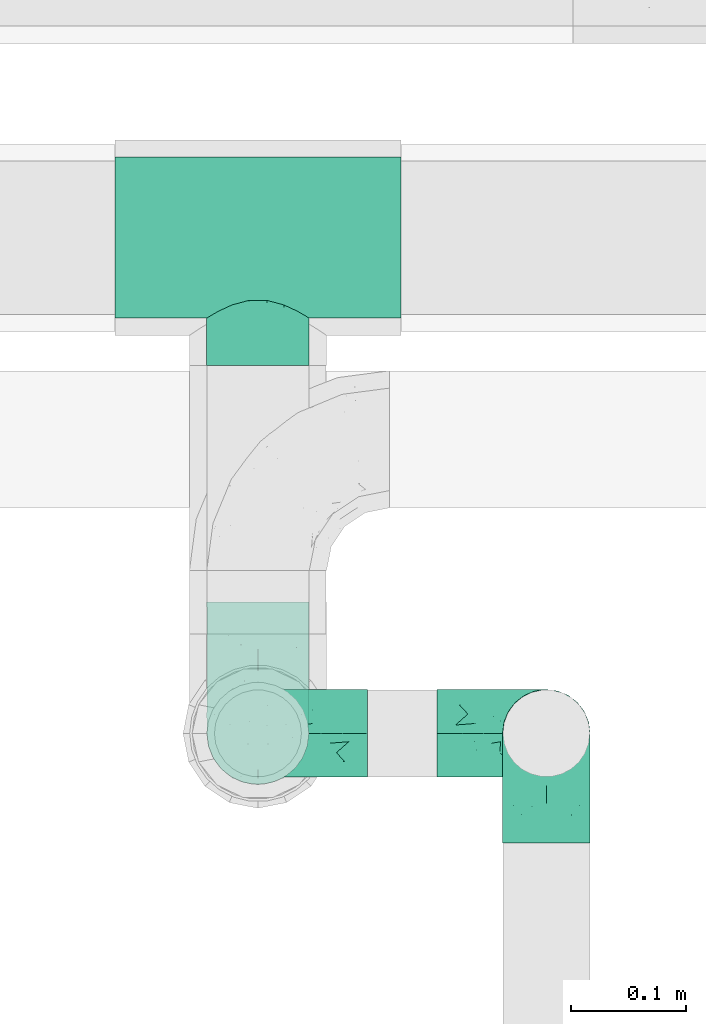
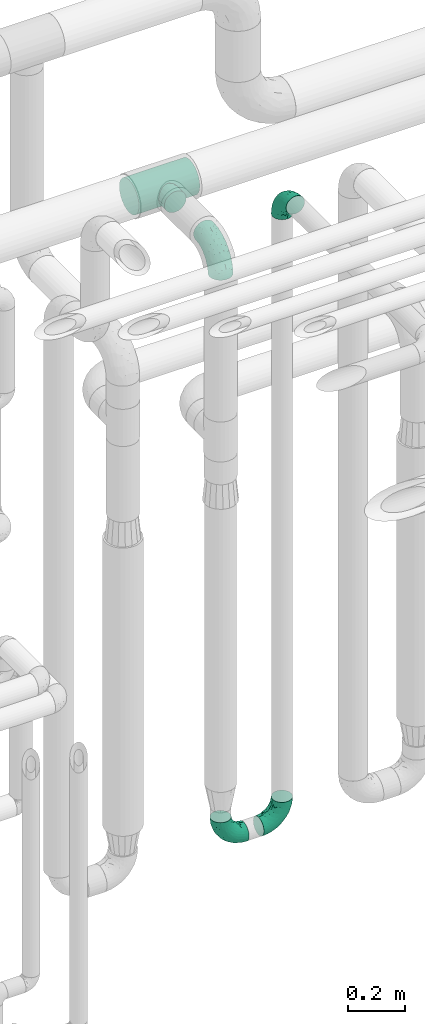
# One storey, part 706 of 827: 5 flow fittings.
"""IFC2X3 building model written with IfcOpenShell, lengths in millimetres."""

import ifcopenshell
import ifcopenshell.guid

model = None  # the IFC model being written
_history = None  # IfcOwnerHistory: only IFC2X3 demands one
_inside = {}  # id of a spatial element -> (the spatial element, [elements in it])
_under = {}  # id of a project, library or spatial element -> (it, [spatial elements below it])
_declared = {}  # id of a project -> (the project, [libraries it declares])
_typed = {}  # id of a type object -> (the type object, [elements of that type])
_made_of = {}  # id of a material, layer set ... -> (it, [elements and type objects made of it])


def new_model(schema):
    """Start an empty IFC model of exactly this schema.

    Asked for "IFC4X3", IfcOpenShell would pick the latest addendum, in which some entities
    have other attributes; the version numbers below select the first issue.
    IFC2X3 requires an IfcOwnerHistory on every rooted entity: one is made here for all.
    """
    global model, _history
    if schema == "IFC4X3":
        model = ifcopenshell.file(schema_version=(4, 3, 0, 0))
    else:
        model = ifcopenshell.file(schema=schema)
    _inside.clear()
    _under.clear()
    _declared.clear()
    _typed.clear()
    _made_of.clear()
    _history = None
    if model.schema == "IFC2X3":
        org = make("IfcOrganization", Name="unknown")
        user = make(
            "IfcPersonAndOrganization",
            ThePerson=make("IfcPerson", FamilyName="unknown"),
            TheOrganization=org,
        )
        app = make(
            "IfcApplication",
            ApplicationDeveloper=org,
            Version="unknown",
            ApplicationFullName="unknown",
            ApplicationIdentifier="unknown",
        )
        _history = make(
            "IfcOwnerHistory",
            OwningUser=user,
            OwningApplication=app,
            ChangeAction="ADDED",
            CreationDate=0,
        )
    return model


def make(cls, **values):
    """One entity of the class cls with the attributes given. An attribute that is None is left unset."""
    return model.create_entity(
        cls, **{name: value for name, value in values.items() if value is not None}
    )


def entity(cls, *values):
    """Any entity or typed value of the class cls, its attributes in the order of the schema. None: left unset."""
    e = model.create_entity(cls)
    for i, value in enumerate(values):
        if value is not None:
            e[i] = value
    return e


def rooted(cls, **values):
    """An entity with a GlobalId (a new one), such as an element, a storey or a relation."""
    return make(cls, GlobalId=ifcopenshell.guid.new(), OwnerHistory=_history, **values)


def si_unit(unit_type, name, prefix=None):
    """IfcSIUnit, for example si_unit("LENGTHUNIT", "METRE", prefix="MILLI")."""
    return make("IfcSIUnit", UnitType=unit_type, Prefix=prefix, Name=name)


def converted_unit(unit_type, name, factor, base, dimensions=None, offset=None):
    """IfcConversionBasedUnit, such as the inch: factor (a typed value) times the base unit."""
    return make(
        "IfcConversionBasedUnit"
        if offset is None
        else "IfcConversionBasedUnitWithOffset",
        ConversionOffset=offset,
        Dimensions=None
        if dimensions is None
        else entity("IfcDimensionalExponents", *dimensions),
        UnitType=unit_type,
        Name=name,
        ConversionFactor=make(
            "IfcMeasureWithUnit", ValueComponent=factor, UnitComponent=base
        ),
    )


def derived_unit(unit_type, elements):
    """IfcDerivedUnit: a product of units, each with its exponent."""
    return make(
        "IfcDerivedUnit",
        Elements=[
            make("IfcDerivedUnitElement", Unit=unit, Exponent=power)
            for unit, power in elements
        ],
        UnitType=unit_type,
    )


def assignment(units):
    """IfcUnitAssignment: the units of a project."""
    return None if units is None else make("IfcUnitAssignment", Units=units)


def point(xyz):
    """IfcCartesianPoint."""
    return None if xyz is None else make("IfcCartesianPoint", Coordinates=xyz)


def direction(xyz):
    """IfcDirection."""
    return None if xyz is None else make("IfcDirection", DirectionRatios=xyz)


def frame(location, z_axis=None, x_axis=None):
    """IfcAxis2Placement3D, a coordinate frame: its origin and axes. An axis left out is left unset."""
    return make(
        "IfcAxis2Placement3D",
        Location=point(location),
        Axis=direction(z_axis),
        RefDirection=direction(x_axis),
    )


def origin():
    """The frame at (0, 0, 0) with its axes left unset."""
    return frame((0.0, 0.0, 0.0))


def place(relative_to, where):
    """IfcLocalPlacement: puts the frame where relative to a parent placement (None: the world)."""
    return make(
        "IfcLocalPlacement", PlacementRelTo=relative_to, RelativePlacement=where
    )


def context(
    kind, dimensions, precision=None, world=None, true_north=None, identifier=None
):
    """IfcGeometricRepresentationContext, for example the 3D "Model" context."""
    return make(
        "IfcGeometricRepresentationContext",
        ContextIdentifier=identifier,
        ContextType=kind,
        CoordinateSpaceDimension=dimensions,
        Precision=precision,
        WorldCoordinateSystem=world,
        TrueNorth=true_north,
    )


def subcontext(parent, identifier, kind, view, scale=None):
    """IfcGeometricRepresentationSubContext, for example "Body" below "Model"."""
    return make(
        "IfcGeometricRepresentationSubContext",
        ContextIdentifier=identifier,
        ContextType=kind,
        ParentContext=parent,
        TargetScale=scale,
        TargetView=view,
    )


def project(units=None, contexts=None):
    """IfcProject with its units and contexts."""
    return rooted(
        "IfcProject",
        Name="project",
        RepresentationContexts=contexts,
        UnitsInContext=assignment(units),
    )


def spatial(cls, under=None, at=None, **own):
    """A site, building, storey or space (cls), placed at a placement, below another one or the project."""
    s = rooted(cls, ObjectPlacement=at, **own)
    if under is not None:
        _under.setdefault(under.id(), (under, []))[1].append(s)
    return s


def faces_of(points, faces, orient=None, outer=None):
    """IfcFace entities. A face is a list of loops; a loop is a list of indices into points, from 0.

    orient and outer hold one flag for each loop. By default every Orientation is true, the
    first loop of a face is its IfcFaceOuterBound and the others are IfcFaceBound.
    """
    made = []
    for i, loops in enumerate(faces):
        bounds = []
        for j, loop in enumerate(loops):
            is_outer = j == 0 if outer is None else outer[i][j]
            bounds.append(
                make(
                    "IfcFaceOuterBound" if is_outer else "IfcFaceBound",
                    Bound=make("IfcPolyLoop", Polygon=[points[k] for k in loop]),
                    Orientation=True if orient is None else orient[i][j],
                )
            )
        made.append(make("IfcFace", Bounds=bounds))
    return made


def faceted_brep(points, faces, orient=None, outer=None, voids=None):
    """IfcFacetedBrep: a solid bounded by flat faces; with voids (closed shells), ...WithVoids."""
    shared = [point(p) for p in points]
    hull = make("IfcClosedShell", CfsFaces=faces_of(shared, faces, orient, outer))
    if voids is None:
        return make("IfcFacetedBrep", Outer=hull)
    return make(
        "IfcFacetedBrepWithVoids",
        Outer=hull,
        Voids=[
            make(cls, CfsFaces=faces_of(shared, fs, o, b)) for cls, fs, o, b in voids
        ],
    )


def shape(context_of_items, identifier, shape_type, items):
    """IfcShapeRepresentation: the items that make up one representation, for example the "Body"."""
    return make(
        "IfcShapeRepresentation",
        ContextOfItems=context_of_items,
        RepresentationIdentifier=identifier,
        RepresentationType=shape_type,
        Items=items,
    )


def source(mapping_origin, context_of_items, identifier, shape_type, items):
    """IfcRepresentationMap: a shape defined once, which mapped items show again and again."""
    return make(
        "IfcRepresentationMap",
        MappingOrigin=mapping_origin,
        MappedRepresentation=shape(context_of_items, identifier, shape_type, items),
    )


def transform(
    local_origin,
    x_axis=None,
    y_axis=None,
    z_axis=None,
    scale=None,
    scale2=None,
    scale3=None,
    uniform=True,
):
    """IfcCartesianTransformationOperator3D, or its non-uniform kind. x_axis, y_axis, z_axis: its Axis1, 2, 3."""
    if uniform:
        return make(
            "IfcCartesianTransformationOperator3D",
            Axis1=direction(x_axis),
            Axis2=direction(y_axis),
            LocalOrigin=point(local_origin),
            Scale=scale,
            Axis3=direction(z_axis),
        )
    return make(
        "IfcCartesianTransformationOperator3DnonUniform",
        Axis1=direction(x_axis),
        Axis2=direction(y_axis),
        LocalOrigin=point(local_origin),
        Scale=scale,
        Axis3=direction(z_axis),
        Scale2=scale2,
        Scale3=scale3,
    )


def mapped(mapping_source, mapping_target):
    """IfcMappedItem: shows the shape of a source again, moved by a transform."""
    return make(
        "IfcMappedItem", MappingSource=mapping_source, MappingTarget=mapping_target
    )


def material(Name=None, Category=None):
    """IfcMaterial."""
    return make("IfcMaterial", Name=Name, Category=Category)


def made_of(thing, what):
    """Note that an element or type object is made of a material, layer set ...; save() writes the relation."""
    if what is not None:
        _made_of.setdefault(what.id(), (what, []))[1].append(thing)
    return thing


def type_object(cls, material=None, **own):
    """A type object (cls), such as IfcWallType, which elements share."""
    return made_of(rooted(cls, **own), material)


def type_shapes(of_type, sources):
    """Give a type object the sources (RepresentationMaps) that its elements show as mapped items."""
    of_type.RepresentationMaps = sources


def element(
    cls,
    number,
    at=None,
    inside=None,
    cuts=None,
    type_object=None,
    material=None,
    context=None,
    identifier="Body",
    shape_type=None,
    held_by="IfcProductDefinitionShape",
    body=None,
    shapes=None,
    **own,
):
    """One element of the class cls, such as IfcWall. Its Tag is "e" and its number.

    at: its placement. inside: the storey or other place that contains it. cuts: it is an
    opening in that element (IfcRelVoidsElement). A single representation is given by context,
    identifier, shape_type and body (its items); several are given by shapes. held_by: the class
    of the entity that holds the representations. save() writes the other relations.
    """
    e = rooted(cls, Tag="e%d" % number, ObjectPlacement=at, **own)
    if body is not None:
        shapes = [shape(context, identifier, shape_type, body)]
    if shapes is not None:
        e.Representation = make(held_by, Representations=shapes)
    if inside is not None:
        _inside.setdefault(inside.id(), (inside, []))[1].append(e)
    if cuts is not None:
        rooted(
            "IfcRelVoidsElement", RelatingBuildingElement=cuts, RelatedOpeningElement=e
        )
    if type_object is not None:
        _typed.setdefault(type_object.id(), (type_object, []))[1].append(e)
    return made_of(e, material)


def aggregate(whole, parts):
    """IfcRelAggregates: a whole, such as a stair, and the parts it consists of."""
    return rooted("IfcRelAggregates", RelatingObject=whole, RelatedObjects=parts)


def save(model, path):
    """Write the relations noted so far, then the file.

    IfcRelAggregates (storeys below a building ...), IfcRelContainedInSpatialStructure (elements
    in a storey), IfcRelDefinesByType, IfcRelAssociatesMaterial and IfcRelDeclares: one each for
    every whole, place, type object, material and project.
    """
    for whole, parts in _under.values():
        aggregate(whole, parts)
    for where, things in _inside.values():
        rooted(
            "IfcRelContainedInSpatialStructure",
            RelatedElements=things,
            RelatingStructure=where,
        )
    for kind, things in _typed.values():
        rooted("IfcRelDefinesByType", RelatedObjects=things, RelatingType=kind)
    for what, things in _made_of.values():
        rooted("IfcRelAssociatesMaterial", RelatedObjects=things, RelatingMaterial=what)
    for by, libraries in _declared.values():
        rooted("IfcRelDeclares", RelatingContext=by, RelatedDefinitions=libraries)
    model.write(path)


model = new_model("IFC2X3")

# Units and contexts
model_context = context("Model", 3, precision=0.01, world=origin(), true_north=direction((6.12303176911189e-17, 1.0)))
body_context = subcontext(model_context, "Body", "Model", "MODEL_VIEW")
ifc_project = project(units=[si_unit("LENGTHUNIT", "METRE", prefix="MILLI"), si_unit("AREAUNIT", "SQUARE_METRE"), si_unit("VOLUMEUNIT", "CUBIC_METRE"), converted_unit("PLANEANGLEUNIT", "DEGREE", entity("IfcRatioMeasure", 0.0174532925199433), si_unit("PLANEANGLEUNIT", "RADIAN"), dimensions=[0, 0, 0, 0, 0, 0, 0]), si_unit("MASSUNIT", "GRAM", prefix="KILO"), derived_unit("MASSDENSITYUNIT", [(si_unit("MASSUNIT", "GRAM", prefix="KILO"), 1), (si_unit("LENGTHUNIT", "METRE"), -3)]), derived_unit("MOMENTOFINERTIAUNIT", [(si_unit("LENGTHUNIT", "METRE"), 4)]), si_unit("TIMEUNIT", "SECOND"), si_unit("FREQUENCYUNIT", "HERTZ"), si_unit("THERMODYNAMICTEMPERATUREUNIT", "DEGREE_CELSIUS"), derived_unit("THERMALTRANSMITTANCEUNIT", [(si_unit("MASSUNIT", "GRAM", prefix="KILO"), 1), (si_unit("THERMODYNAMICTEMPERATUREUNIT", "KELVIN"), -1), (si_unit("TIMEUNIT", "SECOND"), -3)]), derived_unit("VOLUMETRICFLOWRATEUNIT", [(si_unit("LENGTHUNIT", "METRE"), 3), (si_unit("TIMEUNIT", "SECOND"), -1)]), derived_unit("MASSFLOWRATEUNIT", [(si_unit("MASSUNIT", "GRAM", prefix="KILO"), 1), (si_unit("TIMEUNIT", "SECOND"), -1)]), derived_unit("ROTATIONALFREQUENCYUNIT", [(si_unit("TIMEUNIT", "SECOND"), -1)]), si_unit("ELECTRICCURRENTUNIT", "AMPERE"), si_unit("ELECTRICVOLTAGEUNIT", "VOLT"), si_unit("POWERUNIT", "WATT"), si_unit("FORCEUNIT", "NEWTON", prefix="KILO"), si_unit("ILLUMINANCEUNIT", "LUX"), si_unit("LUMINOUSFLUXUNIT", "LUMEN"), si_unit("LUMINOUSINTENSITYUNIT", "CANDELA"), derived_unit("USERDEFINED", [(si_unit("MASSUNIT", "GRAM", prefix="KILO"), -1), (si_unit("LENGTHUNIT", "METRE"), -2), (si_unit("TIMEUNIT", "SECOND"), 3), (si_unit("LUMINOUSFLUXUNIT", "LUMEN"), 1)]), derived_unit("LINEARVELOCITYUNIT", [(si_unit("LENGTHUNIT", "METRE"), 1), (si_unit("TIMEUNIT", "SECOND"), -1)]), si_unit("PRESSUREUNIT", "PASCAL"), derived_unit("USERDEFINED", [(si_unit("LENGTHUNIT", "METRE"), -2), (si_unit("MASSUNIT", "GRAM", prefix="KILO"), 1), (si_unit("TIMEUNIT", "SECOND"), -2)]), derived_unit("LINEARFORCEUNIT", [(si_unit("MASSUNIT", "GRAM", prefix="KILO"), 1), (si_unit("LENGTHUNIT", "METRE"), 1), (si_unit("TIMEUNIT", "SECOND"), -2), (si_unit("LENGTHUNIT", "METRE"), -1)]), derived_unit("PLANARFORCEUNIT", [(si_unit("MASSUNIT", "GRAM", prefix="KILO"), 1), (si_unit("LENGTHUNIT", "METRE"), 1), (si_unit("TIMEUNIT", "SECOND"), -2), (si_unit("LENGTHUNIT", "METRE"), -2)])], contexts=[model_context])

# Site, building, storey
site_placement = place(None, origin())
site = spatial("IfcSite", under=ifc_project, at=site_placement, CompositionType="ELEMENT")
building_placement = place(site_placement, origin())
building = spatial("IfcBuilding", under=site, at=building_placement, CompositionType="ELEMENT")
storey_placement = place(building_placement, frame((0.0, 0.0, 28200.0)))
storey = spatial("IfcBuildingStorey", under=building, at=storey_placement, Name="08", CompositionType="ELEMENT", Elevation=28200.0)

# Flow fittings
ifc_material = material()
pipe_fitting_type_1 = type_object("IfcPipeFittingType", Name="ADSK_1", PredefinedType="NOTDEFINED", material=ifc_material)
shared_shape_1 = source(origin(), body_context, "Body", "Brep", [
    faceted_brep([(-95.0, 19.02, -32.95), (-95.0, 9.85, -36.75), (-95.0, 0.0, -38.05), (-95.0, -9.85, -36.75), (-95.0, -19.03, -32.95), (-95.0, -26.91, -26.91), (-95.0, -32.95, -19.03), (-95.0, -36.75, -9.85), (-95.0, -38.05, 0.0), (-95.0, -36.75, 9.85), (-95.0, -32.95, 19.02), (-95.0, -26.91, 26.91), (-95.0, -19.03, 32.95), (-95.0, -9.85, 36.75), (-95.0, 0.0, 38.05), (-95.0, 9.85, 36.75), (-95.0, 19.02, 32.95), (-95.0, 26.91, 26.91), (-95.0, 32.95, 19.02), (-95.0, 36.75, 9.85), (-95.0, 38.05, 0.0), (-95.0, 36.75, -9.85), (-95.0, 32.95, -19.03), (-95.0, 26.91, -26.91), (0.0, 95.0, -38.05), (-9.85, 95.0, -36.75), (-19.02, 95.0, -32.95), (-26.91, 95.0, -26.91), (-32.95, 95.0, -19.03), (-36.75, 95.0, -9.85), (-38.05, 95.0, 0.0), (-36.75, 95.0, 9.85), (-32.95, 95.0, 19.02), (-26.91, 95.0, 26.91), (-19.02, 95.0, 32.95), (-9.85, 95.0, 36.75), (0.0, 95.0, 38.05), (9.85, 95.0, 36.75), (19.03, 95.0, 32.95), (26.91, 95.0, 26.91), (32.95, 95.0, 19.02), (36.75, 95.0, 9.85), (38.05, 95.0, 0.0), (36.75, 95.0, -9.85), (32.95, 95.0, -19.03), (26.91, 95.0, -26.91), (19.03, 95.0, -32.95), (9.85, 95.0, -36.75), (-7.99, -4.96, 6.3), (-0.92, 0.92, 0.0), (4.62, 8.1, 8.01), (-76.19, -35.57, 0.0), (-64.32, -32.32, 12.43), (20.51, 62.45, 28.68), (-60.56, -33.52, 0.0), (-70.4, -13.47, 34.42), (-39.61, -5.88, 32.32), (-49.6, 2.07, 37.1), (-70.34, -28.81, 21.71), (14.64, 40.81, 26.5), (5.88, 39.61, 32.32), (3.59, 20.77, 25.31), (-40.45, 68.06, 16.75), (-62.45, -20.51, 28.68), (-44.52, -26.87, 0.0), (-28.47, -20.22, 0.0), (-26.43, -17.83, 8.75), (-76.1, 39.63, 10.76), (-72.74, 37.58, 18.19), (-60.35, 46.18, 14.61), (-13.4, 13.4, 32.12), (-20.77, -3.59, 25.31), (-14.66, 81.47, 35.56), (-6.22, 71.26, 37.92), (-57.5, 42.48, 22.79), (-15.0, 34.74, 37.7), (-27.1, 12.08, 36.05), (-9.2, 28.81, 35.63), (-79.98, 23.7, 30.95), (-73.68, -4.3, 37.48), (-30.74, 21.67, 37.97), (-62.36, 47.59, 6.79), (-72.71, 32.83, 24.69), (-67.42, 7.02, 37.95), (-32.13, 75.27, 24.51), (-43.46, 51.47, 26.26), (-24.98, 73.15, 31.29), (20.59, 41.28, 19.85), (7.79, 16.09, 15.86), (-73.21, 42.39, 0.0), (-54.73, 54.73, 0.0), (-73.44, 15.79, 35.79), (-5.94, 4.32, 20.43), (28.81, 70.34, 21.71), (32.32, 64.32, 12.43), (-53.59, 26.2, 35.09), (-52.02, 19.31, 37.21), (21.38, 33.53, 10.34), (26.87, 44.52, 0.0), (-48.28, 12.14, 38.05), (4.3, 73.68, 37.48), (-44.08, -25.52, 12.79), (-41.28, -20.59, 19.85), (35.57, 76.19, 0.0), (-47.26, 54.3, 20.18), (-47.4, 61.99, 8.58), (-42.39, 73.21, 0.0), (-39.67, 78.86, 7.21), (-45.69, 36.84, 33.11), (-32.83, 50.13, 33.35), (13.47, 70.4, 34.42), (-18.25, 63.73, 36.07), (-40.63, -13.75, 27.22), (-16.63, 46.37, 37.95), (-53.47, 38.79, 28.59), (-26.07, 48.54, 36.15), (-34.51, 34.51, 36.86), (-2.07, 49.6, 37.1), (-22.79, -10.49, 19.23), (-61.73, 28.67, 31.87), (9.65, 14.7, 0.0), (20.22, 28.47, 0.0), (33.52, 60.56, 0.0), (-11.42, -5.44, 13.25), (-14.7, -9.65, 0.0), (-81.47, 14.66, -35.56), (-62.45, -20.51, -28.68), (-71.26, 6.22, -37.92), (-75.27, 32.13, -24.51), (-73.15, 24.98, -31.29), (13.47, 70.4, -34.42), (5.88, 39.61, -32.32), (-2.07, 49.6, -37.1), (-78.86, 39.67, -7.21), (-70.4, -13.47, -34.42), (-39.61, -5.88, -32.32), (-61.99, 47.4, -8.58), (32.32, 64.32, -12.43), (28.81, 70.34, -21.71), (-63.73, 18.25, -36.07), (-50.13, 32.83, -33.35), (4.3, 73.68, -37.48), (-7.02, 67.42, -37.95), (-39.63, 76.1, -10.76), (-46.18, 60.35, -14.61), (-47.59, 62.36, -6.79), (-64.32, -32.32, -12.43), (-26.2, 53.59, -35.09), (-15.79, 73.44, -35.79), (-19.31, 52.02, -37.21), (-37.58, 72.74, -18.19), (-70.34, -28.81, -21.71), (-42.48, 57.5, -22.79), (-38.79, 53.47, -28.59), (-51.47, 43.46, -26.26), (-32.83, 72.71, -24.69), (-46.37, 16.63, -37.95), (-73.68, -4.3, -37.48), (-41.28, -20.59, -19.85), (-44.08, -25.52, -12.79), (13.75, 40.63, -27.22), (20.51, 62.45, -28.68), (-68.06, 40.45, -16.75), (-54.3, 47.26, -20.18), (-12.14, 48.28, -38.05), (-21.67, 30.74, -37.97), (-36.84, 45.69, -33.11), (-11.42, -5.44, -13.25), (7.79, 16.09, -15.86), (4.62, 8.1, -8.01), (-23.7, 79.98, -30.95), (-26.43, -17.83, -8.75), (-7.99, -4.96, -6.3), (-40.81, -14.64, -26.5), (-20.77, -3.59, -25.31), (-34.74, 15.0, -37.7), (-12.08, 27.1, -36.05), (-28.81, 9.2, -35.63), (-22.79, -10.49, -19.23), (21.38, 33.53, -10.34), (20.59, 41.28, -19.85), (-48.54, 26.07, -36.15), (-49.6, 2.07, -37.1), (-13.4, 13.4, -32.12), (3.59, 20.77, -25.31), (-28.67, 61.73, -31.87), (-34.51, 34.51, -36.86), (-5.94, 4.32, -20.43)], [[[0, 1, 2, 3, 4, 5, 6, 7, 8, 9, 10, 11, 12, 13, 14, 15, 16, 17, 18, 19, 20, 21, 22, 23]], [[24, 25, 26, 27, 28, 29, 30, 31, 32, 33, 34, 35, 36, 37, 38, 39, 40, 41, 42, 43, 44, 45, 46, 47]], [[48, 49, 50]], [[51, 52, 9]], [[53, 39, 38]], [[9, 52, 10]], [[54, 52, 51]], [[55, 56, 57]], [[11, 10, 58]], [[59, 60, 61]], [[32, 31, 62]], [[63, 12, 11]], [[63, 55, 12]], [[64, 65, 66]], [[67, 68, 69]], [[70, 56, 71]], [[35, 72, 73]], [[69, 68, 74]], [[75, 76, 77]], [[16, 78, 17]], [[13, 79, 14]], [[76, 75, 80]], [[67, 69, 81]], [[18, 17, 82]], [[14, 79, 83]], [[20, 19, 67]], [[84, 85, 86]], [[87, 61, 88]], [[89, 81, 90]], [[18, 82, 68]], [[15, 91, 16]], [[14, 83, 15]], [[71, 92, 61]], [[17, 78, 82]], [[93, 87, 94]], [[95, 91, 96]], [[97, 98, 94]], [[86, 72, 34]], [[96, 99, 80]], [[37, 36, 100]], [[40, 39, 93]], [[40, 94, 41]], [[64, 66, 101]], [[93, 94, 40]], [[58, 102, 63]], [[94, 103, 41]], [[94, 87, 97]], [[104, 69, 74]], [[34, 33, 86]], [[105, 69, 104]], [[52, 58, 10]], [[106, 107, 30]], [[108, 109, 85]], [[105, 106, 90]], [[53, 110, 60]], [[86, 111, 72]], [[86, 109, 111]], [[33, 84, 86]], [[12, 55, 13]], [[112, 56, 63]], [[110, 38, 37]], [[34, 72, 35]], [[36, 35, 73]], [[111, 113, 73]], [[105, 107, 106]], [[110, 53, 38]], [[74, 114, 85]], [[91, 15, 83]], [[105, 90, 81]], [[107, 62, 31]], [[33, 32, 84]], [[115, 109, 116]], [[111, 115, 113]], [[100, 73, 117]], [[56, 55, 63]], [[79, 55, 57]], [[102, 118, 112]], [[56, 70, 76]], [[100, 110, 37]], [[117, 77, 60]], [[117, 60, 110]], [[60, 70, 61]], [[58, 52, 101]], [[63, 11, 58]], [[39, 53, 93]], [[87, 93, 53]], [[96, 91, 83]], [[78, 91, 119]], [[32, 62, 84]], [[84, 62, 104]], [[86, 85, 109]], [[85, 114, 108]], [[80, 113, 116]], [[117, 73, 113]], [[80, 116, 96]], [[80, 57, 76]], [[71, 112, 118]], [[61, 87, 59]], [[62, 107, 105]], [[97, 120, 121]], [[70, 71, 61]], [[71, 118, 92]], [[73, 100, 36]], [[110, 100, 117]], [[55, 79, 13]], [[83, 79, 57]], [[96, 83, 99]], [[116, 108, 95]], [[50, 97, 88]], [[97, 87, 88]], [[50, 49, 120]], [[122, 94, 98]], [[89, 20, 67]], [[105, 81, 69]], [[89, 67, 81]], [[68, 19, 18]], [[68, 67, 19]], [[74, 68, 82]], [[114, 82, 119]], [[74, 85, 104]], [[82, 114, 74]], [[114, 119, 108]], [[95, 108, 119]], [[116, 109, 108]], [[123, 48, 50]], [[97, 50, 120]], [[123, 50, 88]], [[91, 95, 119]], [[116, 95, 96]], [[84, 104, 85]], [[104, 62, 105]], [[83, 57, 99]], [[57, 80, 99]], [[66, 48, 123]], [[66, 124, 48]], [[118, 66, 123]], [[124, 66, 65]], [[66, 118, 101]], [[54, 64, 52]], [[124, 49, 48]], [[30, 107, 31]], [[91, 78, 16]], [[82, 78, 119]], [[56, 76, 57]], [[77, 76, 70]], [[60, 77, 70]], [[77, 117, 75]], [[117, 113, 75]], [[113, 80, 75]], [[9, 8, 51]], [[103, 94, 122]], [[103, 42, 41]], [[73, 72, 111]], [[113, 115, 116]], [[111, 109, 115]], [[102, 112, 63]], [[71, 56, 112]], [[118, 102, 101]], [[92, 123, 88]], [[123, 92, 118]], [[61, 92, 88]], [[87, 53, 59]], [[60, 59, 53]], [[97, 121, 98]], [[58, 101, 102]], [[64, 101, 52]], [[125, 1, 0]], [[126, 5, 4]], [[2, 1, 127]], [[1, 125, 127]], [[128, 129, 23]], [[130, 131, 132]], [[89, 133, 20]], [[126, 134, 135]], [[136, 89, 90]], [[137, 138, 44]], [[139, 129, 140]], [[24, 141, 142]], [[143, 144, 145]], [[125, 129, 139]], [[6, 146, 7]], [[147, 148, 149]], [[146, 51, 7]], [[143, 150, 144]], [[146, 6, 151]], [[152, 153, 154]], [[126, 4, 134]], [[0, 23, 129]], [[28, 155, 150]], [[43, 42, 103]], [[54, 146, 64]], [[139, 156, 127]], [[157, 3, 2]], [[151, 158, 159]], [[160, 131, 161]], [[22, 21, 162]], [[136, 144, 163]], [[149, 164, 165]], [[24, 142, 25]], [[166, 140, 154]], [[154, 129, 128]], [[143, 30, 29]], [[167, 168, 169]], [[155, 28, 27]], [[26, 170, 27]], [[171, 167, 172]], [[26, 25, 148]], [[27, 170, 155]], [[173, 135, 174]], [[144, 150, 152]], [[175, 176, 177]], [[24, 47, 141]], [[45, 161, 46]], [[148, 25, 142]], [[176, 175, 165]], [[64, 159, 171]], [[138, 45, 44]], [[130, 46, 161]], [[137, 44, 43]], [[178, 159, 158]], [[137, 103, 122]], [[163, 144, 152]], [[136, 133, 89]], [[103, 137, 43]], [[6, 5, 151]], [[178, 158, 173]], [[134, 4, 3]], [[178, 173, 174]], [[137, 98, 179]], [[145, 90, 106]], [[138, 180, 161]], [[46, 130, 47]], [[136, 90, 145]], [[133, 162, 21]], [[23, 22, 128]], [[139, 140, 181]], [[139, 181, 156]], [[157, 127, 182]], [[157, 134, 3]], [[182, 177, 135]], [[182, 135, 134]], [[135, 183, 174]], [[131, 130, 161]], [[141, 130, 132]], [[160, 180, 184]], [[131, 183, 176]], [[5, 126, 151]], [[158, 151, 126]], [[180, 138, 137]], [[161, 45, 138]], [[149, 148, 142]], [[170, 148, 185]], [[22, 162, 128]], [[128, 162, 163]], [[129, 154, 140]], [[154, 153, 166]], [[165, 156, 186]], [[182, 127, 156]], [[165, 186, 149]], [[165, 132, 176]], [[131, 184, 183]], [[187, 167, 178]], [[184, 168, 187]], [[167, 169, 172]], [[184, 180, 168]], [[174, 183, 184]], [[127, 157, 2]], [[134, 157, 182]], [[130, 141, 47]], [[142, 141, 132]], [[149, 142, 164]], [[186, 166, 147]], [[180, 179, 168]], [[169, 179, 120]], [[137, 179, 180]], [[179, 121, 120]], [[106, 30, 143]], [[136, 145, 144]], [[106, 143, 145]], [[150, 29, 28]], [[150, 143, 29]], [[152, 150, 155]], [[153, 155, 185]], [[152, 154, 163]], [[155, 153, 152]], [[153, 185, 166]], [[147, 166, 185]], [[186, 140, 166]], [[169, 120, 49]], [[169, 49, 172]], [[179, 169, 168]], [[148, 147, 185]], [[186, 147, 149]], [[128, 163, 154]], [[163, 162, 136]], [[142, 132, 164]], [[132, 165, 164]], [[171, 124, 65]], [[124, 171, 172]], [[64, 146, 159]], [[171, 159, 178]], [[171, 65, 64]], [[172, 49, 124]], [[162, 133, 136]], [[20, 133, 21]], [[148, 170, 26]], [[155, 170, 185]], [[131, 176, 132]], [[177, 176, 183]], [[135, 177, 183]], [[177, 182, 175]], [[182, 156, 175]], [[156, 165, 175]], [[51, 146, 54]], [[51, 8, 7]], [[129, 125, 0]], [[127, 125, 139]], [[140, 186, 181]], [[156, 181, 186]], [[158, 126, 173]], [[135, 173, 126]], [[187, 178, 174]], [[171, 178, 167]], [[184, 187, 174]], [[167, 187, 168]], [[180, 160, 161]], [[184, 131, 160]], [[98, 137, 122]], [[98, 121, 179]], [[151, 159, 146]]]),
])
type_shapes(pipe_fitting_type_1, [shared_shape_1])
for number, where, z_axis, x_axis, name in (
    (1, (57698.13, 17500.0, 3050.0), (1.0, 0.0, 0.0), (0.0, 0.0, 1.0), "ADSK_1"),
    (2, (57698.13, 17500.0, 350.0), (0.0, 1.0, 0.0), (0.0, 0.0, -1.0), "ADSK_1"),
    (3, (57447.89, 17500.0, 350.0), (0.0, 1.0, 0.0), (-1.0, 0.0, 0.0), "ADSK_1"),
):
    element("IfcFlowFitting", number, at=place(storey_placement, frame(where, z_axis=z_axis, x_axis=x_axis)), inside=storey, type_object=pipe_fitting_type_1, material=ifc_material, Name=name, ObjectType="ADSK_1", context=body_context, shape_type="MappedRepresentation", body=[
        mapped(shared_shape_1, transform((0.0, 0.0, 0.0), scale=1.0)),
    ])
pipe_fitting_type_2 = type_object("IfcPipeFittingType", Name="ADSK_1", PredefinedType="NOTDEFINED", material=ifc_material)
shared_shape_2 = source(origin(), body_context, "Body", "Brep", [
    faceted_brep([(-124.0, 18.08, -67.47), (-124.0, 0.0, -69.85), (-124.0, -18.08, -67.47), (-124.0, -34.93, -60.49), (-124.0, -49.39, -49.39), (-124.0, -60.49, -34.93), (-124.0, -63.98, -26.5), (-124.0, -67.47, -18.08), (-124.0, -69.85, 0.0), (-124.0, -67.47, 18.08), (-124.0, -63.98, 26.5), (-124.0, -60.49, 34.92), (-124.0, -49.39, 49.39), (-124.0, -34.93, 60.49), (-124.0, -18.08, 67.47), (-124.0, 0.0, 69.85), (-124.0, 18.08, 67.47), (-124.0, 34.92, 60.49), (-124.0, 49.39, 49.39), (-124.0, 60.49, 34.92), (-124.0, 67.47, 18.08), (-124.0, 69.85, 0.0), (-124.0, 67.47, -18.08), (-124.0, 60.49, -34.93), (-124.0, 49.39, -49.39), (-124.0, 34.92, -60.49), (124.0, 49.39, -49.39), (124.0, 60.49, -34.93), (124.0, 67.47, -18.08), (124.0, 69.85, 0.0), (124.0, 67.47, 18.08), (124.0, 60.49, 34.92), (124.0, 49.39, 49.39), (124.0, 34.92, 60.49), (124.0, 18.08, 67.47), (124.0, 0.0, 69.85), (124.0, -18.08, 67.47), (124.0, -34.93, 60.49), (124.0, -49.39, 49.39), (124.0, -60.49, 34.92), (124.0, -63.98, 26.5), (124.0, -67.47, 18.08), (124.0, -69.85, 0.0), (124.0, -67.47, -18.08), (124.0, -63.98, -26.5), (124.0, -60.49, -34.93), (124.0, -49.39, -49.39), (124.0, -34.93, -60.49), (124.0, -18.08, -67.47), (124.0, 0.0, -69.85), (124.0, 18.08, -67.47), (124.0, 34.92, -60.49), (41.64, -68.1, 15.55), (43.05, -68.97, 7.77), (44.45, -69.85, 0.0), (33.91, -63.66, 28.74), (22.41, -58.36, 38.39), (7.93, -54.46, 43.74), (15.17, -56.41, 41.06), (-33.91, -63.66, 28.74), (-44.45, -69.85, 0.0), (-43.05, -68.97, 7.77), (-41.64, -68.1, 15.55), (-22.41, -58.36, 38.39), (-7.93, -54.46, 43.74), (0.0, -54.46, 43.74), (22.41, -58.36, -38.39), (-33.91, -63.66, -28.74), (15.17, -56.41, -41.06), (7.93, -54.46, -43.74), (33.91, -63.66, -28.74), (41.64, -68.1, -15.55), (43.05, -68.97, -7.77), (-7.93, -54.46, -43.74), (-22.41, -58.36, -38.39), (0.0, -54.46, -43.74), (-41.64, -68.1, -15.55), (-43.05, -68.97, -7.77), (31.43, -111.0, -31.43), (38.49, -111.0, -22.23), (42.94, -111.0, -11.5), (44.45, -111.0, 0.0), (42.94, -111.0, 11.5), (38.49, -111.0, 22.22), (31.43, -111.0, 31.43), (22.23, -111.0, 38.49), (11.5, -111.0, 42.94), (0.0, -111.0, 44.45), (-11.5, -111.0, 42.94), (-22.22, -111.0, 38.49), (-31.43, -111.0, 31.43), (-38.49, -111.0, 22.22), (-42.94, -111.0, 11.5), (-44.45, -111.0, 0.0), (-42.94, -111.0, -11.5), (-38.49, -111.0, -22.23), (-31.43, -111.0, -31.43), (-22.22, -111.0, -38.49), (-11.5, -111.0, -42.94), (0.0, -111.0, -44.45), (11.5, -111.0, -42.94), (22.23, -111.0, -38.49)], [[[0, 1, 2, 3, 4, 5, 6, 7, 8, 9, 10, 11, 12, 13, 14, 15, 16, 17, 18, 19, 20, 21, 22, 23, 24, 25]], [[26, 27, 28, 29, 30, 31, 32, 33, 34, 35, 36, 37, 38, 39, 40, 41, 42, 43, 44, 45, 46, 47, 48, 49, 50, 51]], [[42, 41, 52]], [[42, 52, 53, 54]], [[41, 55, 52]], [[39, 38, 56]], [[56, 55, 39]], [[38, 57, 58, 56]], [[38, 12, 57]], [[39, 55, 41, 40]], [[59, 11, 10, 9]], [[8, 60, 61, 62]], [[9, 8, 62]], [[62, 59, 9]], [[63, 64, 12]], [[63, 11, 59]], [[11, 63, 12]], [[12, 64, 65, 57]], [[38, 37, 13, 12]], [[15, 14, 36, 35]], [[14, 13, 37, 36]], [[16, 15, 35, 34]], [[31, 30, 20, 19]], [[18, 17, 33, 32]], [[19, 18, 32, 31]], [[34, 33, 17, 16]], [[21, 20, 30, 29]], [[22, 28, 27, 23]], [[27, 26, 24, 23]], [[29, 28, 22, 21]], [[49, 48, 2, 1]], [[0, 25, 51, 50]], [[1, 0, 50, 49]], [[26, 51, 25, 24]], [[47, 3, 2, 48]], [[47, 46, 4, 3]], [[46, 45, 66]], [[67, 7, 6, 5]], [[46, 66, 68, 69]], [[45, 70, 66]], [[46, 69, 4]], [[43, 42, 71]], [[71, 70, 43]], [[42, 54, 72, 71]], [[43, 70, 45, 44]], [[73, 74, 4]], [[5, 4, 74]], [[74, 67, 5]], [[4, 69, 75, 73]], [[67, 76, 7]], [[76, 8, 7]], [[8, 76, 77, 60]], [[78, 79, 80, 81, 82, 83, 84, 85, 86, 87, 88, 89, 90, 91, 92, 93, 94, 95, 96, 97, 98, 99, 100, 101]], [[87, 64, 88]], [[63, 90, 89]], [[90, 59, 91]], [[63, 89, 88]], [[61, 60, 93]], [[93, 92, 61]], [[92, 91, 62]], [[92, 62, 61]], [[59, 62, 91]], [[90, 63, 59]], [[53, 81, 54]], [[88, 64, 63]], [[87, 57, 65, 64]], [[85, 56, 58]], [[84, 56, 85]], [[52, 83, 82]], [[84, 83, 55]], [[57, 87, 86]], [[58, 57, 86]], [[85, 58, 86]], [[56, 84, 55]], [[55, 83, 52]], [[53, 52, 82]], [[81, 53, 82]], [[80, 72, 81]], [[68, 101, 100]], [[68, 66, 101]], [[80, 71, 72]], [[80, 79, 71]], [[77, 76, 94]], [[78, 70, 79]], [[72, 54, 81]], [[71, 79, 70]], [[99, 69, 100]], [[66, 70, 78]], [[100, 69, 68]], [[66, 78, 101]], [[99, 73, 75, 69]], [[74, 98, 97]], [[96, 74, 97]], [[76, 95, 94]], [[96, 95, 67]], [[73, 99, 98]], [[98, 74, 73]], [[74, 96, 67]], [[67, 95, 76]], [[93, 77, 94]], [[77, 93, 60]]]),
])
type_shapes(pipe_fitting_type_2, [shared_shape_2])
flow_fitting_1_placement = place(storey_placement, frame((57447.89, 17930.1, 2899.96)))
element("IfcFlowFitting", 4, at=flow_fitting_1_placement, inside=storey, type_object=pipe_fitting_type_2, material=ifc_material, Name="ADSK_1", ObjectType="ADSK_1", context=body_context, shape_type="MappedRepresentation", body=[
    mapped(shared_shape_2, transform((0.0, 0.0, 0.0), scale=1.0)),
])
pipe_fitting_type_3 = type_object("IfcPipeFittingType", Name="ADSK_1", PredefinedType="NOTDEFINED", material=ifc_material)
shared_shape_3 = source(origin(), body_context, "Body", "Brep", [
    faceted_brep([(-114.0, 22.22, -38.49), (-114.0, 11.5, -42.94), (-114.0, 0.0, -44.45), (-114.0, -11.5, -42.94), (-114.0, -22.23, -38.49), (-114.0, -31.43, -31.43), (-114.0, -38.49, -22.23), (-114.0, -42.94, -11.5), (-114.0, -44.45, 0.0), (-114.0, -42.94, 11.5), (-114.0, -38.49, 22.22), (-114.0, -31.43, 31.43), (-114.0, -22.23, 38.49), (-114.0, -11.5, 42.94), (-114.0, 0.0, 44.45), (-114.0, 11.5, 42.94), (-114.0, 22.22, 38.49), (-114.0, 31.43, 31.43), (-114.0, 38.49, 22.22), (-114.0, 42.94, 11.5), (-114.0, 44.45, 0.0), (-114.0, 42.94, -11.5), (-114.0, 38.49, -22.23), (-114.0, 31.43, -31.43), (0.0, 114.0, -44.45), (-11.5, 114.0, -42.94), (-22.22, 114.0, -38.49), (-31.43, 114.0, -31.43), (-38.49, 114.0, -22.23), (-42.94, 114.0, -11.5), (-44.45, 114.0, 0.0), (-42.94, 114.0, 11.5), (-38.49, 114.0, 22.22), (-31.43, 114.0, 31.43), (-22.22, 114.0, 38.49), (-11.5, 114.0, 42.94), (0.0, 114.0, 44.45), (11.5, 114.0, 42.94), (22.23, 114.0, 38.49), (31.43, 114.0, 31.43), (38.49, 114.0, 22.22), (42.94, 114.0, 11.5), (44.45, 114.0, 0.0), (42.94, 114.0, -11.5), (38.49, 114.0, -22.23), (31.43, 114.0, -31.43), (22.23, 114.0, -38.49), (11.5, 114.0, -42.94), (-24.5, -15.82, 8.24), (-7.18, -2.06, 7.97), (-13.53, -4.79, 15.72), (-92.03, -41.56, 0.0), (-77.08, -37.56, 14.57), (23.74, 74.96, 33.55), (-72.99, -39.05, 0.0), (-84.56, -15.6, 40.23), (-47.88, -6.37, 37.83), (-59.8, 2.77, 43.37), (-84.46, -33.54, 25.41), (16.69, 49.28, 31.02), (6.37, 47.88, 37.83), (3.35, 25.47, 29.77), (-47.43, 81.55, 19.51), (-74.96, -23.74, 33.55), (-46.77, -27.89, 11.23), (-53.88, -31.14, 0.0), (-87.05, 38.52, 28.81), (-63.44, 55.78, 24.79), (-93.24, 43.37, 18.58), (-16.67, 16.67, 37.64), (-25.47, -3.35, 29.77), (-17.2, 97.7, 41.53), (-7.42, 85.54, 44.3), (-67.09, 46.29, 31.23), (-18.08, 42.1, 44.06), (-32.93, 14.9, 42.17), (-11.54, 34.94, 41.69), (-95.7, 27.79, 36.14), (-88.55, -4.92, 43.79), (-2.77, 59.8, 43.37), (-87.65, 48.44, 9.87), (-81.01, 8.37, 44.32), (-37.63, 90.26, 28.6), (-51.29, 61.56, 30.59), (-29.32, 87.72, 36.52), (23.49, 49.5, 23.28), (8.19, 20.11, 19.18), (-70.06, 58.9, 9.01), (-87.38, 49.74, 0.0), (-88.15, 18.57, 41.8), (-7.96, 6.22, 24.33), (33.54, 84.46, 25.41), (37.56, 77.08, 14.57), (-58.37, 34.98, 40.92), (-62.38, 23.02, 43.45), (24.15, 39.93, 12.16), (31.14, 53.88, 0.0), (-58.13, 14.61, 44.45), (-37.17, 26.09, 44.37), (4.92, 88.55, 43.79), (-34.77, -23.22, 0.0), (-49.5, -23.49, 23.28), (41.56, 92.03, 0.0), (-57.83, 66.03, 19.12), (-71.84, 54.46, 17.06), (-46.46, 94.23, 8.51), (-49.74, 87.38, 0.0), (-38.96, 59.98, 38.88), (-55.29, 46.95, 36.83), (-64.82, 64.82, 0.0), (-55.88, 73.75, 10.01), (15.6, 84.56, 40.23), (-21.6, 76.38, 42.11), (-49.04, -15.53, 31.95), (-19.97, 55.59, 44.33), (-73.61, 33.95, 37.2), (-31.05, 58.14, 42.19), (-41.3, 41.3, 43.02), (-27.36, -11.22, 22.61), (9.28, 15.84, 8.73), (23.22, 34.77, 0.0), (39.05, 72.99, 0.0), (-1.96, 1.96, 0.0), (10.63, 18.37, 0.0), (-18.37, -10.63, 0.0), (-97.7, 17.2, -41.53), (9.28, 15.84, -8.73), (-13.53, -4.79, -15.72), (8.19, 20.11, -19.18), (-85.54, 7.42, -44.3), (-8.37, 81.01, -44.32), (-90.26, 37.63, -28.6), (-87.72, 29.32, -36.52), (-27.79, 95.7, -36.14), (-38.52, 87.05, -28.81), (-94.23, 46.46, -8.51), (-84.56, -15.6, -40.23), (-73.75, 55.88, -10.01), (-10.19, -4.86, -7.51), (-76.38, 21.6, -42.11), (-59.98, 38.96, -38.88), (-49.28, -16.69, -31.02), (-47.88, -6.37, -37.83), (-25.47, -3.35, -29.77), (-34.98, 58.37, -40.92), (-46.95, 55.29, -36.83), (-77.08, -37.56, -14.57), (-18.57, 88.15, -41.8), (-23.02, 62.38, -43.45), (-55.78, 63.44, -24.79), (-43.37, 93.24, -18.58), (-84.46, -33.54, -25.41), (-33.95, 73.61, -37.2), (-46.29, 67.09, -31.23), (-74.96, -23.74, -33.55), (-48.44, 87.65, -9.87), (-45.44, -27.06, -11.87), (-88.55, -4.92, -43.79), (-49.5, -23.49, -23.28), (-14.61, 58.13, -44.45), (-26.09, 37.17, -44.37), (15.6, 84.56, -40.23), (6.37, 47.88, -37.83), (-2.77, 59.8, -43.37), (-81.55, 47.43, -19.51), (33.54, 84.46, -25.41), (23.49, 49.5, -23.28), (23.74, 74.96, -33.55), (-42.1, 18.08, -44.06), (-14.9, 32.93, -42.17), (-34.94, 11.54, -41.69), (-61.56, 51.29, -30.59), (-27.36, -11.22, -22.61), (37.56, 77.08, -14.57), (4.92, 88.55, -43.79), (-59.8, 2.77, -43.37), (-66.03, 57.83, -19.12), (-54.46, 71.84, -17.06), (-55.59, 19.97, -44.33), (-58.9, 70.06, -9.01), (24.15, 39.93, -12.16), (15.53, 49.04, -31.95), (-58.14, 31.05, -42.19), (-41.3, 41.3, -43.02), (-16.67, 16.67, -37.64), (3.35, 25.47, -29.77), (-7.96, 6.22, -24.33), (-26.36, -16.33, -11.05)], [[[0, 1, 2, 3, 4, 5, 6, 7, 8, 9, 10, 11, 12, 13, 14, 15, 16, 17, 18, 19, 20, 21, 22, 23]], [[24, 25, 26, 27, 28, 29, 30, 31, 32, 33, 34, 35, 36, 37, 38, 39, 40, 41, 42, 43, 44, 45, 46, 47]], [[48, 49, 50]], [[51, 52, 9]], [[53, 39, 38]], [[9, 52, 10]], [[54, 52, 51]], [[55, 56, 57]], [[11, 10, 58]], [[59, 60, 61]], [[32, 31, 62]], [[63, 12, 11]], [[63, 55, 12]], [[64, 52, 65]], [[66, 67, 68]], [[69, 56, 70]], [[35, 71, 72]], [[67, 66, 73]], [[74, 75, 76]], [[16, 77, 17]], [[13, 78, 14]], [[76, 79, 74]], [[68, 80, 19]], [[18, 17, 66]], [[14, 78, 81]], [[20, 19, 80]], [[82, 83, 84]], [[85, 61, 86]], [[87, 88, 80]], [[18, 68, 19]], [[15, 89, 16]], [[14, 81, 15]], [[70, 90, 61]], [[17, 77, 66]], [[91, 85, 92]], [[93, 89, 94]], [[95, 96, 92]], [[84, 71, 34]], [[94, 97, 98]], [[37, 36, 99]], [[40, 39, 91]], [[40, 92, 41]], [[65, 100, 64]], [[91, 92, 40]], [[58, 101, 63]], [[92, 102, 41]], [[92, 85, 95]], [[67, 103, 104]], [[34, 33, 84]], [[105, 62, 31]], [[52, 58, 10]], [[106, 105, 30]], [[93, 107, 108]], [[106, 109, 110]], [[53, 111, 60]], [[84, 112, 71]], [[84, 107, 112]], [[33, 82, 84]], [[12, 55, 13]], [[113, 56, 63]], [[111, 38, 37]], [[34, 71, 35]], [[36, 35, 72]], [[112, 114, 72]], [[110, 105, 106]], [[111, 53, 38]], [[115, 108, 73]], [[89, 15, 81]], [[104, 87, 80]], [[110, 87, 103]], [[33, 32, 82]], [[116, 107, 117]], [[112, 116, 114]], [[99, 72, 79]], [[56, 55, 63]], [[78, 55, 57]], [[101, 118, 113]], [[56, 69, 75]], [[99, 111, 37]], [[79, 76, 60]], [[79, 60, 111]], [[60, 69, 61]], [[101, 58, 52]], [[63, 11, 58]], [[39, 53, 91]], [[85, 91, 53]], [[94, 89, 81]], [[77, 89, 115]], [[84, 83, 107]], [[93, 108, 115]], [[98, 114, 117]], [[79, 72, 114]], [[98, 117, 94]], [[98, 57, 75]], [[32, 62, 82]], [[83, 82, 62]], [[70, 113, 118]], [[61, 85, 59]], [[48, 64, 100]], [[95, 119, 120]], [[69, 70, 61]], [[70, 118, 90]], [[72, 99, 36]], [[111, 99, 79]], [[55, 78, 13]], [[81, 78, 57]], [[94, 81, 97]], [[93, 94, 117]], [[66, 68, 18]], [[80, 68, 104]], [[103, 87, 104]], [[80, 88, 20]], [[50, 49, 119]], [[95, 85, 86]], [[119, 95, 86]], [[121, 92, 96]], [[50, 119, 86]], [[119, 122, 123, 120]], [[110, 109, 87]], [[88, 87, 109]], [[62, 105, 110]], [[30, 105, 31]], [[81, 57, 97]], [[57, 98, 97]], [[107, 93, 117]], [[89, 93, 115]], [[107, 83, 108]], [[73, 108, 83]], [[67, 73, 83]], [[115, 73, 66]], [[103, 83, 62]], [[67, 104, 68]], [[83, 103, 67]], [[110, 103, 62]], [[89, 77, 16]], [[66, 77, 115]], [[56, 75, 57]], [[76, 75, 69]], [[60, 76, 69]], [[79, 114, 74]], [[114, 98, 74]], [[75, 74, 98]], [[9, 8, 51]], [[102, 92, 121]], [[102, 42, 41]], [[72, 71, 112]], [[52, 54, 65]], [[64, 48, 118]], [[101, 52, 64]], [[124, 122, 49]], [[118, 48, 50]], [[49, 48, 124]], [[119, 49, 122]], [[48, 100, 124]], [[114, 116, 117]], [[112, 107, 116]], [[101, 113, 63]], [[70, 56, 113]], [[64, 118, 101]], [[90, 50, 86]], [[50, 90, 118]], [[61, 90, 86]], [[85, 53, 59]], [[60, 59, 53]], [[95, 120, 96]], [[125, 1, 0]], [[126, 127, 128]], [[2, 1, 129]], [[24, 130, 25]], [[131, 132, 23]], [[27, 133, 134]], [[88, 135, 20]], [[136, 4, 3]], [[88, 109, 137]], [[138, 122, 124]], [[139, 132, 140]], [[141, 142, 143]], [[144, 140, 145]], [[125, 132, 139]], [[6, 146, 7]], [[144, 147, 148]], [[146, 51, 7]], [[134, 149, 150]], [[146, 6, 151]], [[152, 145, 153]], [[154, 4, 136]], [[154, 136, 142]], [[150, 155, 29]], [[43, 42, 102]], [[65, 146, 156]], [[0, 23, 132]], [[157, 3, 2]], [[146, 151, 158]], [[148, 159, 160]], [[161, 162, 163]], [[135, 164, 21]], [[165, 166, 167]], [[168, 169, 170]], [[147, 25, 130]], [[171, 132, 131]], [[155, 30, 29]], [[172, 141, 143]], [[134, 28, 27]], [[149, 134, 153]], [[173, 165, 44]], [[26, 25, 147]], [[22, 21, 164]], [[24, 174, 130]], [[133, 27, 26]], [[170, 175, 168]], [[24, 47, 174]], [[45, 167, 46]], [[28, 150, 29]], [[1, 125, 129]], [[156, 100, 65]], [[165, 45, 44]], [[161, 46, 167]], [[173, 44, 43]], [[6, 5, 151]], [[173, 102, 121]], [[137, 135, 88]], [[46, 161, 47]], [[102, 173, 43]], [[149, 176, 177]], [[172, 158, 141]], [[139, 178, 129]], [[154, 5, 4]], [[156, 146, 158]], [[106, 155, 179]], [[173, 96, 180]], [[181, 162, 167]], [[177, 179, 155]], [[137, 179, 176]], [[23, 22, 131]], [[182, 140, 183]], [[139, 182, 178]], [[157, 129, 175]], [[157, 136, 3]], [[175, 170, 142]], [[175, 142, 136]], [[142, 184, 143]], [[162, 161, 167]], [[174, 161, 163]], [[181, 166, 185]], [[162, 184, 169]], [[5, 154, 151]], [[158, 151, 154]], [[166, 165, 173]], [[167, 45, 165]], [[148, 147, 130]], [[133, 147, 152]], [[132, 171, 140]], [[144, 145, 152]], [[160, 178, 183]], [[175, 129, 178]], [[160, 183, 148]], [[160, 163, 169]], [[22, 164, 131]], [[171, 131, 164]], [[162, 185, 184]], [[186, 127, 172]], [[185, 128, 186]], [[156, 187, 100]], [[185, 166, 128]], [[143, 184, 185]], [[129, 157, 2]], [[136, 157, 175]], [[161, 174, 47]], [[130, 174, 163]], [[148, 130, 159]], [[144, 148, 183]], [[134, 150, 28]], [[155, 150, 177]], [[176, 179, 177]], [[155, 106, 30]], [[166, 180, 128]], [[128, 180, 126]], [[173, 180, 166]], [[126, 120, 123, 122]], [[120, 126, 180]], [[122, 138, 126]], [[137, 109, 179]], [[106, 179, 109]], [[164, 135, 137]], [[20, 135, 21]], [[130, 163, 159]], [[163, 160, 159]], [[140, 144, 183]], [[147, 144, 152]], [[140, 171, 145]], [[153, 145, 171]], [[149, 153, 171]], [[152, 153, 134]], [[176, 171, 164]], [[149, 177, 150]], [[171, 176, 149]], [[137, 176, 164]], [[147, 133, 26]], [[134, 133, 152]], [[162, 169, 163]], [[170, 169, 184]], [[142, 170, 184]], [[175, 178, 168]], [[178, 160, 168]], [[169, 168, 160]], [[51, 146, 54]], [[51, 8, 7]], [[132, 125, 0]], [[129, 125, 139]], [[156, 158, 172]], [[65, 54, 146]], [[178, 182, 183]], [[139, 140, 182]], [[158, 154, 141]], [[142, 141, 154]], [[186, 172, 143]], [[172, 127, 187]], [[185, 186, 143]], [[127, 186, 128]], [[187, 127, 138]], [[124, 100, 187]], [[126, 138, 127]], [[187, 138, 124]], [[172, 187, 156]], [[166, 181, 167]], [[185, 162, 181]], [[96, 173, 121]], [[96, 120, 180]]]),
])
type_shapes(pipe_fitting_type_3, [shared_shape_3])
flow_fitting_2_placement = place(storey_placement, frame((57447.89, 17500.0, 2900.0), z_axis=(1.0, 0.0, 0.0), x_axis=(0.0, -1.0, 0.0)))
element("IfcFlowFitting", 5, at=flow_fitting_2_placement, inside=storey, type_object=pipe_fitting_type_3, material=ifc_material, Name="ADSK_1", ObjectType="ADSK_1", context=body_context, shape_type="MappedRepresentation", body=[
    mapped(shared_shape_3, transform((0.0, 0.0, 0.0), scale=1.0)),
])

save(model, "model.ifc")
